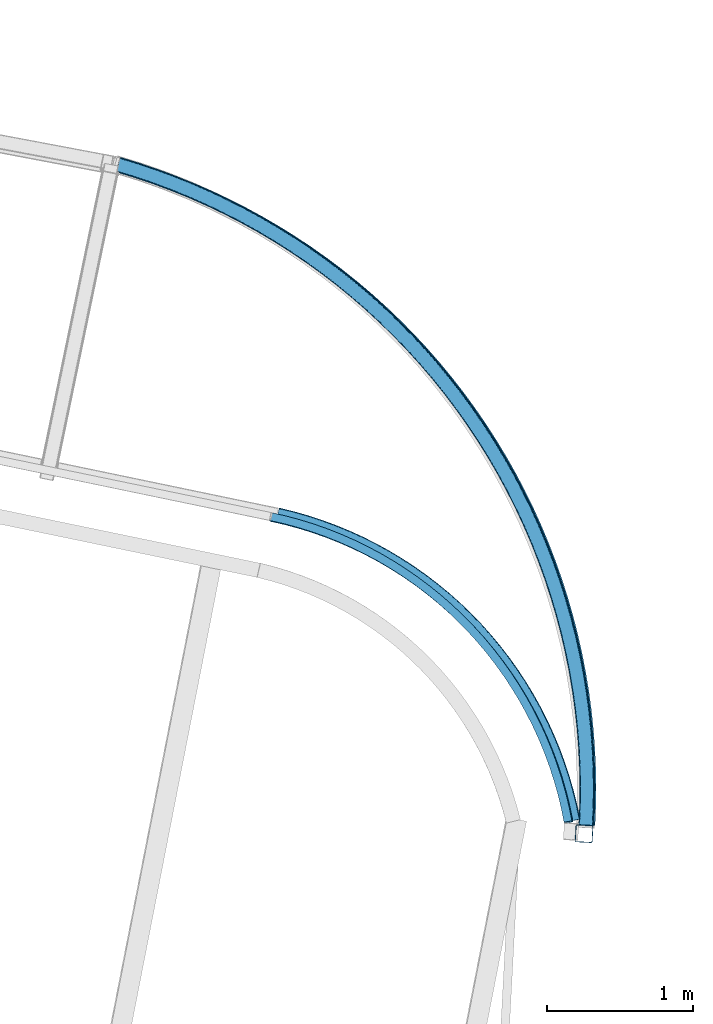
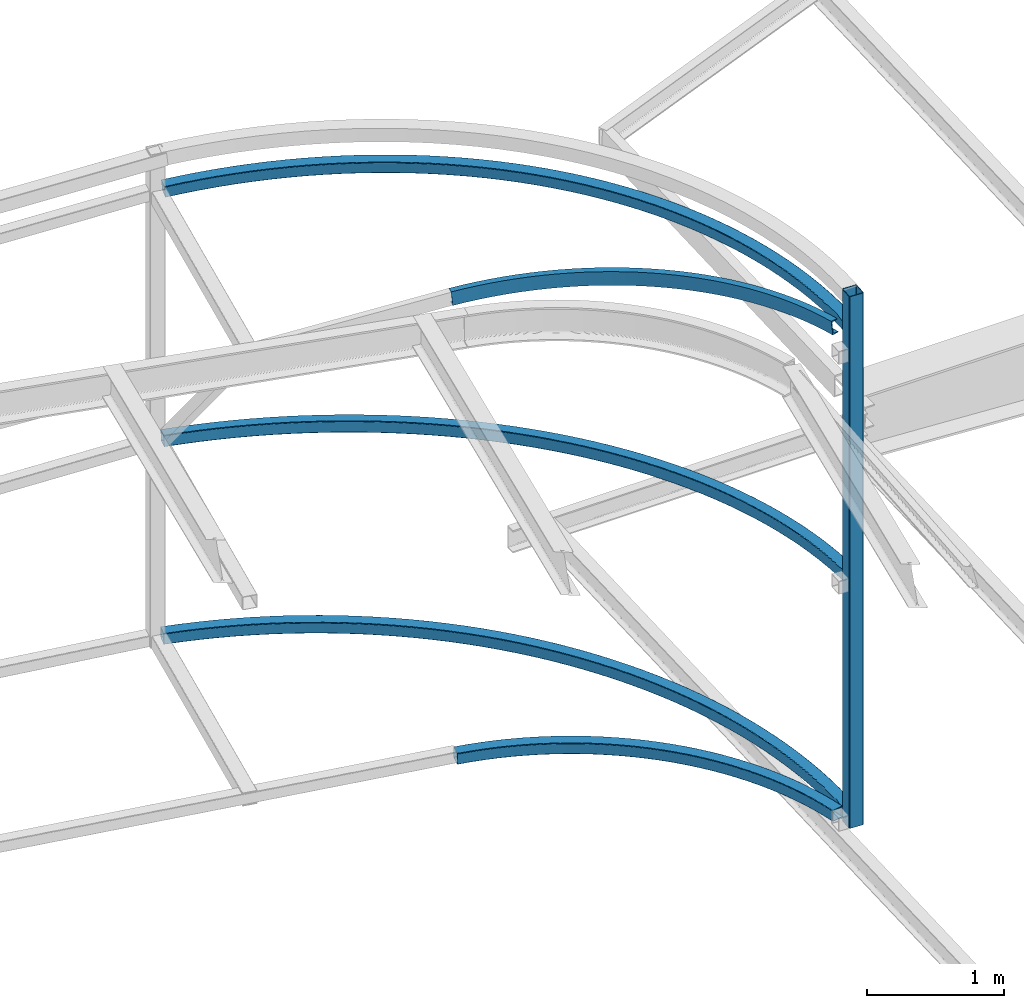
# One storey, part 113 of 215: 6 beams, 6 elements without a shape of their own.
"""IFC2X3 building model written with IfcOpenShell, lengths in millimetres."""

from ifc_helpers import new_model, entity, si_unit, frame, origin_with_axes, origin_2d_with_axis, place, context, subcontext, project, spatial, hollow_rectangle, extrude, material, type_object, element, aggregate, save


model = new_model("IFC2X3")

# Units and contexts
model_context = context("Model", 3, precision=1e-05, world=origin_with_axes())
body_context = subcontext(model_context, "Body", "Model", "MODEL_VIEW")
ifc_project = project(units=[si_unit("LENGTHUNIT", "METRE", prefix="MILLI"), si_unit("AREAUNIT", "SQUARE_METRE"), si_unit("VOLUMEUNIT", "CUBIC_METRE"), si_unit("MASSUNIT", "GRAM", prefix="KILO"), si_unit("TIMEUNIT", "SECOND"), si_unit("PLANEANGLEUNIT", "RADIAN"), si_unit("SOLIDANGLEUNIT", "STERADIAN"), si_unit("THERMODYNAMICTEMPERATUREUNIT", "DEGREE_CELSIUS"), si_unit("LUMINOUSINTENSITYUNIT", "LUMEN")], contexts=[model_context])

# Site, building, storey
site_placement = place(None, origin_with_axes())
site = spatial("IfcSite", under=ifc_project, at=site_placement, CompositionType="ELEMENT")
building_placement = place(site_placement, origin_with_axes())
building = spatial("IfcBuilding", under=site, at=building_placement, Name="Undefined", CompositionType="ELEMENT")
storey_placement = place(building_placement, origin_with_axes())
storey = spatial("IfcBuildingStorey", under=building, at=storey_placement, Name="Undefined", CompositionType="ELEMENT", Elevation=0.0)

# Assembly, beam
assembly_1_placement = place(storey_placement, origin_with_axes())
assembly_1 = element("IfcElementAssembly", 1, at=assembly_1_placement, inside=storey, Name="Steel Assembly", AssemblyPlace="NOTDEFINED", PredefinedType="RIGID_FRAME")
ifc_material = material(Name="STEEL/S275JR")
beam_type_1 = type_object("IfcBeamType", PredefinedType="NOTDEFINED")
beam_1_placement = place(assembly_1_placement, frame((101391.351661667, 52945.3172030212, 12666.1604793598), z_axis=(-0.0530192000044864, -0.998593493084591, -1.00000033862047e-09), x_axis=(0.0, 0.0, -1.0)))
beam_1 = element("IfcBeam", 2, at=beam_1_placement, type_object=beam_type_1, material=ifc_material, Name="MONTANT", context=body_context, shape_type="SweptSolid", body=[
    extrude(hollow_rectangle(XDim=120.0, YDim=120.0, WallThickness=5.0, InnerFilletRadius=5.0, OuterFilletRadius=10.0, at=origin_2d_with_axis()), frame((4754.68474934304, -1.45519152283669e-11, 0.0), z_axis=(-1.0, 0.0, 0.0), x_axis=(-6.93889390390723e-18, -1.0, -3.46944695195361e-18)), (0.0, 0.0, 1.0), 4754.7),
])
aggregate(assembly_1, [beam_1])

assembly_2_placement = place(storey_placement, origin_with_axes())
assembly_2 = element("IfcElementAssembly", 3, at=assembly_2_placement, inside=storey, Name="Steel Assembly", AssemblyPlace="NOTDEFINED", PredefinedType="RIGID_FRAME")
beam_type_2 = type_object("IfcBeamType", PredefinedType="NOTDEFINED")
beam_2_placement = place(assembly_2_placement, frame((99291.7868044238, 55129.4394792428, 7920.07427987434), z_axis=(0.719209341005711, 0.694789471005526, 0.00234835900001828), x_axis=(0.6946952221968, -0.719160395203732, 0.0143831230040747)))
beam_2 = element("IfcBeam", 4, at=beam_2_placement, type_object=beam_type_2, material=ifc_material, Name="LISSE", context=body_context, shape_type="SweptSolid", body=[
    entity("IfcRevolvedAreaSolid", entity("IfcRectangleHollowProfileDef", "AREA", None, entity("IfcAxis2Placement2D", entity("IfcCartesianPoint", [0.0, 0.0]), entity("IfcDirection", [1.0, 0.0])), 100.0, 100.0, 5.0, 5.0, 10.0), entity("IfcAxis2Placement3D", entity("IfcCartesianPoint", [2912.17805844459, 5.05182364420836e-15, 1.47450882816995e-11]), entity("IfcDirection", [-0.835515052221639, -1.21109400749783e-18, 0.54946755819709]), entity("IfcDirection", [-6.93889390390723e-18, -1.0, -3.46944695195361e-18])), entity("IfcAxis1Placement", entity("IfcCartesianPoint", [0.0, -2650.0, 0.0]), entity("IfcDirection", [1.0, 0.0, 0.0])), 1.16345368492566),
])
aggregate(assembly_2, [beam_2])

assembly_3_placement = place(storey_placement, origin_with_axes())
assembly_3 = element("IfcElementAssembly", 5, at=assembly_3_placement, inside=storey, Name="Steel Assembly", AssemblyPlace="NOTDEFINED", PredefinedType="RIGID_FRAME")
beam_3_placement = place(assembly_3_placement, frame((98199.4701957462, 57530.2900727189, 9684.98069362489), z_axis=(0.817072523776123, 0.573799078842774, -0.0560990909846287), x_axis=(0.576514867202451, -0.813978177285838, 0.0712048790250044)))
beam_3 = element("IfcBeam", 6, at=beam_3_placement, type_object=beam_type_2, material=ifc_material, Name="LISSE", context=body_context, shape_type="SweptSolid", body=[
    entity("IfcRevolvedAreaSolid", entity("IfcRectangleHollowProfileDef", "AREA", None, entity("IfcAxis2Placement2D", entity("IfcCartesianPoint", [0.0, 0.0]), entity("IfcDirection", [1.0, 0.0])), 100.0, 100.0, 5.0, 5.0, 10.0), entity("IfcAxis2Placement3D", entity("IfcCartesianPoint", [5559.38730478811, 7.71519973573069e-14, 1.48894552168051e-11]), entity("IfcDirection", [-0.780904638208158, -1.51716107411969e-17, 0.624650258964956]), entity("IfcDirection", [-6.93889390390723e-18, -1.0, -3.46944695195361e-18])), entity("IfcAxis1Placement", entity("IfcCartesianPoint", [0.0, -4450.0, 0.0]), entity("IfcDirection", [1.0, 0.0, 0.0])), 1.3493671723177),
])
aggregate(assembly_3, [beam_3])

assembly_4_placement = place(storey_placement, origin_with_axes())
assembly_4 = element("IfcElementAssembly", 7, at=assembly_4_placement, inside=storey, Name="Steel Assembly", AssemblyPlace="NOTDEFINED", PredefinedType="RIGID_FRAME")
beam_4_placement = place(assembly_4_placement, frame((98206.4459486853, 57528.7571178251, 11915.0502488991), z_axis=(0.811285087912072, 0.580745790937057, 0.0674598579926885), x_axis=(0.576782930001559, -0.813887484002201, 0.0700615090001896)))
beam_4 = element("IfcBeam", 8, at=beam_4_placement, type_object=beam_type_2, material=ifc_material, Name="LISSE", context=body_context, shape_type="SweptSolid", body=[
    entity("IfcRevolvedAreaSolid", entity("IfcRectangleHollowProfileDef", "AREA", None, entity("IfcAxis2Placement2D", entity("IfcCartesianPoint", [0.0, 0.0]), entity("IfcDirection", [1.0, 0.0])), 100.0, 100.0, 5.0, 5.0, 10.0), entity("IfcAxis2Placement3D", entity("IfcCartesianPoint", [5559.50082174776, -9.09494701772928e-13, 1.39009319585285e-11]), entity("IfcDirection", [-0.780894435465394, 0.0, 0.624663013679523]), entity("IfcDirection", [-6.93889390390723e-18, -1.0, -3.46944695195361e-18])), entity("IfcAxis1Placement", entity("IfcCartesianPoint", [0.0, -4450.0, 0.0]), entity("IfcDirection", [1.0, 0.0, 0.0])), 1.34939983904105),
])
aggregate(assembly_4, [beam_4])

assembly_5_placement = place(storey_placement, origin_with_axes())
assembly_5 = element("IfcElementAssembly", 9, at=assembly_5_placement, inside=storey, Name="Steel Assembly", AssemblyPlace="NOTDEFINED", PredefinedType="RIGID_FRAME")
beam_5_placement = place(assembly_5_placement, frame((98198.0616035838, 57530.3508131568, 7920.32260416605), z_axis=(0.815924912729773, 0.578114394808534, 0.00709107199765171), x_axis=(0.578071007176977, -0.815953560249804, 0.00732790400224349)))
beam_5 = element("IfcBeam", 10, at=beam_5_placement, type_object=beam_type_2, material=ifc_material, Name="LISSE", context=body_context, shape_type="SweptSolid", body=[
    entity("IfcRevolvedAreaSolid", entity("IfcRectangleHollowProfileDef", "AREA", None, entity("IfcAxis2Placement2D", entity("IfcCartesianPoint", [0.0, 0.0]), entity("IfcDirection", [1.0, 0.0])), 100.0, 100.0, 5.0, 5.0, 10.0), entity("IfcAxis2Placement3D", entity("IfcCartesianPoint", [5546.15919017274, -9.09494701772928e-13, -4.11525489875915e-13]), entity("IfcDirection", [-0.782091226453102, 0.0, 0.623163953951994]), entity("IfcDirection", [-6.93889390390723e-18, -1.0, -3.46944695195361e-18])), entity("IfcAxis1Placement", entity("IfcCartesianPoint", [0.0, -4450.0, 0.0]), entity("IfcDirection", [1.0, 0.0, 0.0])), 1.34556343975882),
])
aggregate(assembly_5, [beam_5])

assembly_6_placement = place(storey_placement, origin_with_axes())
assembly_6 = element("IfcElementAssembly", 11, at=assembly_6_placement, inside=storey, Name="Steel Assembly", AssemblyPlace="NOTDEFINED", PredefinedType="RIGID_FRAME")
beam_type_3 = type_object("IfcBeamType", Name="UPN120", PredefinedType="NOTDEFINED")
beam_6_placement = place(assembly_6_placement, frame((99244.165859722, 55115.2884355053, 12046.6687373864), z_axis=(0.0681294209859938, -0.0697851319856454, -0.995232845795324), x_axis=(0.695237208563691, -0.712133162553089, 0.0975273429387951)))
beam_6 = element("IfcBeam", 12, at=beam_6_placement, type_object=beam_type_3, material=ifc_material, ObjectType="UPN120", context=body_context, shape_type="SweptSolid", body=[
    entity("IfcRevolvedAreaSolid", entity("IfcUShapeProfileDef", "AREA", None, entity("IfcAxis2Placement2D", entity("IfcCartesianPoint", [0.0, 0.0]), entity("IfcDirection", [1.0, 0.0])), 120.0, 55.0, 7.0, 9.0, 9.0, 4.5, 0.0798299857122373), entity("IfcAxis2Placement3D", entity("IfcCartesianPoint", [2935.4479278778, -1.45948654419962e-11, -1.77825188008188e-12]), entity("IfcDirection", [-0.830858982622763, -0.556483019502901, -1.29227588143717e-17]), entity("IfcDirection", [0.556483019502902, -0.830858982622763, 5.64401330597986e-18])), entity("IfcAxis1Placement", entity("IfcCartesianPoint", [-2637.5, 0.0, 0.0]), entity("IfcDirection", [-6.93889390390723e-18, -1.0, -3.46944695195361e-18])), 1.1802936493314),
])
aggregate(assembly_6, [beam_6])

save(model, "model.ifc")
